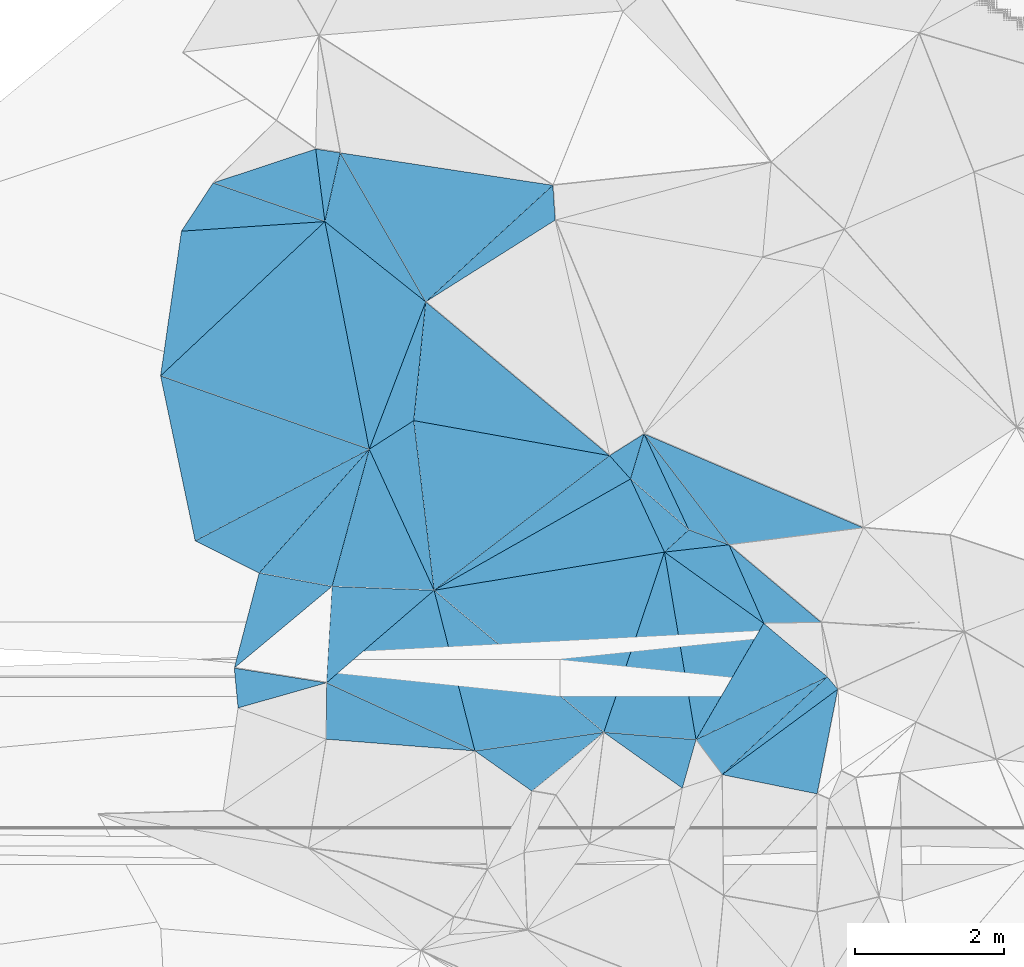
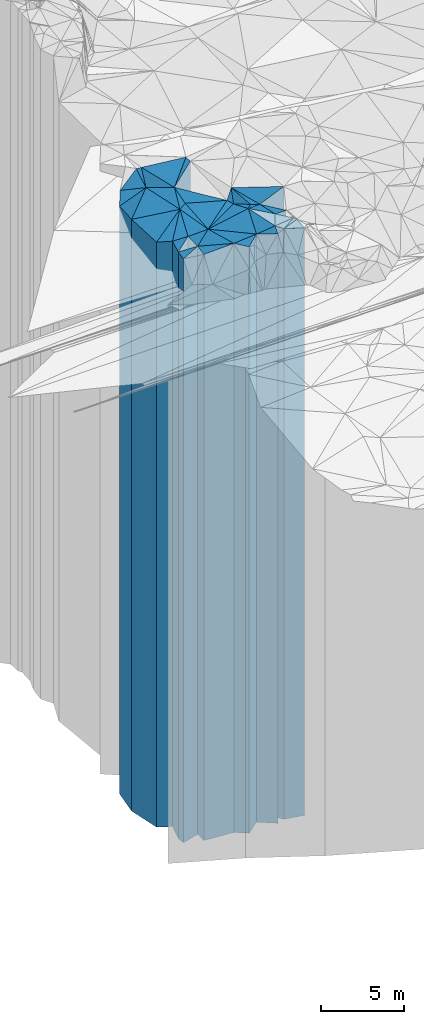
# One storey, part 215 of 275: 42 plates.
"""IFC2X3 building model written with IfcOpenShell, lengths in millimetres."""

import ifcopenshell
import ifcopenshell.guid

model = None  # the IFC model being written
_history = None  # IfcOwnerHistory: only IFC2X3 demands one
_inside = {}  # id of a spatial element -> (the spatial element, [elements in it])
_under = {}  # id of a project, library or spatial element -> (it, [spatial elements below it])
_declared = {}  # id of a project -> (the project, [libraries it declares])
_typed = {}  # id of a type object -> (the type object, [elements of that type])
_made_of = {}  # id of a material, layer set ... -> (it, [elements and type objects made of it])


def new_model(schema):
    """Start an empty IFC model of exactly this schema.

    Asked for "IFC4X3", IfcOpenShell would pick the latest addendum, in which some entities
    have other attributes; the version numbers below select the first issue.
    IFC2X3 requires an IfcOwnerHistory on every rooted entity: one is made here for all.
    """
    global model, _history
    if schema == "IFC4X3":
        model = ifcopenshell.file(schema_version=(4, 3, 0, 0))
    else:
        model = ifcopenshell.file(schema=schema)
    _inside.clear()
    _under.clear()
    _declared.clear()
    _typed.clear()
    _made_of.clear()
    _history = None
    if model.schema == "IFC2X3":
        org = make("IfcOrganization", Name="unknown")
        user = make(
            "IfcPersonAndOrganization",
            ThePerson=make("IfcPerson", FamilyName="unknown"),
            TheOrganization=org,
        )
        app = make(
            "IfcApplication",
            ApplicationDeveloper=org,
            Version="unknown",
            ApplicationFullName="unknown",
            ApplicationIdentifier="unknown",
        )
        _history = make(
            "IfcOwnerHistory",
            OwningUser=user,
            OwningApplication=app,
            ChangeAction="ADDED",
            CreationDate=0,
        )
    return model


def make(cls, **values):
    """One entity of the class cls with the attributes given. An attribute that is None is left unset."""
    return model.create_entity(
        cls, **{name: value for name, value in values.items() if value is not None}
    )


def rooted(cls, **values):
    """An entity with a GlobalId (a new one), such as an element, a storey or a relation."""
    return make(cls, GlobalId=ifcopenshell.guid.new(), OwnerHistory=_history, **values)


def si_unit(unit_type, name, prefix=None):
    """IfcSIUnit, for example si_unit("LENGTHUNIT", "METRE", prefix="MILLI")."""
    return make("IfcSIUnit", UnitType=unit_type, Prefix=prefix, Name=name)


def assignment(units):
    """IfcUnitAssignment: the units of a project."""
    return None if units is None else make("IfcUnitAssignment", Units=units)


def point(xyz):
    """IfcCartesianPoint."""
    return None if xyz is None else make("IfcCartesianPoint", Coordinates=xyz)


def direction(xyz):
    """IfcDirection."""
    return None if xyz is None else make("IfcDirection", DirectionRatios=xyz)


def frame(location, z_axis=None, x_axis=None):
    """IfcAxis2Placement3D, a coordinate frame: its origin and axes. An axis left out is left unset."""
    return make(
        "IfcAxis2Placement3D",
        Location=point(location),
        Axis=direction(z_axis),
        RefDirection=direction(x_axis),
    )


def origin_with_axes():
    """The frame at (0, 0, 0) with the z axis (0, 0, 1) and the x axis (1, 0, 0) written out."""
    return frame((0.0, 0.0, 0.0), z_axis=(0.0, 0.0, 1.0), x_axis=(1.0, 0.0, 0.0))


def place(relative_to, where):
    """IfcLocalPlacement: puts the frame where relative to a parent placement (None: the world)."""
    return make(
        "IfcLocalPlacement", PlacementRelTo=relative_to, RelativePlacement=where
    )


def context(
    kind, dimensions, precision=None, world=None, true_north=None, identifier=None
):
    """IfcGeometricRepresentationContext, for example the 3D "Model" context."""
    return make(
        "IfcGeometricRepresentationContext",
        ContextIdentifier=identifier,
        ContextType=kind,
        CoordinateSpaceDimension=dimensions,
        Precision=precision,
        WorldCoordinateSystem=world,
        TrueNorth=true_north,
    )


def subcontext(parent, identifier, kind, view, scale=None):
    """IfcGeometricRepresentationSubContext, for example "Body" below "Model"."""
    return make(
        "IfcGeometricRepresentationSubContext",
        ContextIdentifier=identifier,
        ContextType=kind,
        ParentContext=parent,
        TargetScale=scale,
        TargetView=view,
    )


def project(units=None, contexts=None):
    """IfcProject with its units and contexts."""
    return rooted(
        "IfcProject",
        Name="project",
        RepresentationContexts=contexts,
        UnitsInContext=assignment(units),
    )


def spatial(cls, under=None, at=None, **own):
    """A site, building, storey or space (cls), placed at a placement, below another one or the project."""
    s = rooted(cls, ObjectPlacement=at, **own)
    if under is not None:
        _under.setdefault(under.id(), (under, []))[1].append(s)
    return s


def faces_of(points, faces, orient=None, outer=None):
    """IfcFace entities. A face is a list of loops; a loop is a list of indices into points, from 0.

    orient and outer hold one flag for each loop. By default every Orientation is true, the
    first loop of a face is its IfcFaceOuterBound and the others are IfcFaceBound.
    """
    made = []
    for i, loops in enumerate(faces):
        bounds = []
        for j, loop in enumerate(loops):
            is_outer = j == 0 if outer is None else outer[i][j]
            bounds.append(
                make(
                    "IfcFaceOuterBound" if is_outer else "IfcFaceBound",
                    Bound=make("IfcPolyLoop", Polygon=[points[k] for k in loop]),
                    Orientation=True if orient is None else orient[i][j],
                )
            )
        made.append(make("IfcFace", Bounds=bounds))
    return made


def faceted_brep(points, faces, orient=None, outer=None, voids=None):
    """IfcFacetedBrep: a solid bounded by flat faces; with voids (closed shells), ...WithVoids."""
    shared = [point(p) for p in points]
    hull = make("IfcClosedShell", CfsFaces=faces_of(shared, faces, orient, outer))
    if voids is None:
        return make("IfcFacetedBrep", Outer=hull)
    return make(
        "IfcFacetedBrepWithVoids",
        Outer=hull,
        Voids=[
            make(cls, CfsFaces=faces_of(shared, fs, o, b)) for cls, fs, o, b in voids
        ],
    )


def shape(context_of_items, identifier, shape_type, items):
    """IfcShapeRepresentation: the items that make up one representation, for example the "Body"."""
    return make(
        "IfcShapeRepresentation",
        ContextOfItems=context_of_items,
        RepresentationIdentifier=identifier,
        RepresentationType=shape_type,
        Items=items,
    )


def material(Name=None, Category=None):
    """IfcMaterial."""
    return make("IfcMaterial", Name=Name, Category=Category)


def made_of(thing, what):
    """Note that an element or type object is made of a material, layer set ...; save() writes the relation."""
    if what is not None:
        _made_of.setdefault(what.id(), (what, []))[1].append(thing)
    return thing


def type_object(cls, material=None, **own):
    """A type object (cls), such as IfcWallType, which elements share."""
    return made_of(rooted(cls, **own), material)


def element(
    cls,
    number,
    at=None,
    inside=None,
    cuts=None,
    type_object=None,
    material=None,
    context=None,
    identifier="Body",
    shape_type=None,
    held_by="IfcProductDefinitionShape",
    body=None,
    shapes=None,
    **own,
):
    """One element of the class cls, such as IfcWall. Its Tag is "e" and its number.

    at: its placement. inside: the storey or other place that contains it. cuts: it is an
    opening in that element (IfcRelVoidsElement). A single representation is given by context,
    identifier, shape_type and body (its items); several are given by shapes. held_by: the class
    of the entity that holds the representations. save() writes the other relations.
    """
    e = rooted(cls, Tag="e%d" % number, ObjectPlacement=at, **own)
    if body is not None:
        shapes = [shape(context, identifier, shape_type, body)]
    if shapes is not None:
        e.Representation = make(held_by, Representations=shapes)
    if inside is not None:
        _inside.setdefault(inside.id(), (inside, []))[1].append(e)
    if cuts is not None:
        rooted(
            "IfcRelVoidsElement", RelatingBuildingElement=cuts, RelatedOpeningElement=e
        )
    if type_object is not None:
        _typed.setdefault(type_object.id(), (type_object, []))[1].append(e)
    return made_of(e, material)


def aggregate(whole, parts):
    """IfcRelAggregates: a whole, such as a stair, and the parts it consists of."""
    return rooted("IfcRelAggregates", RelatingObject=whole, RelatedObjects=parts)


def save(model, path):
    """Write the relations noted so far, then the file.

    IfcRelAggregates (storeys below a building ...), IfcRelContainedInSpatialStructure (elements
    in a storey), IfcRelDefinesByType, IfcRelAssociatesMaterial and IfcRelDeclares: one each for
    every whole, place, type object, material and project.
    """
    for whole, parts in _under.values():
        aggregate(whole, parts)
    for where, things in _inside.values():
        rooted(
            "IfcRelContainedInSpatialStructure",
            RelatedElements=things,
            RelatingStructure=where,
        )
    for kind, things in _typed.values():
        rooted("IfcRelDefinesByType", RelatedObjects=things, RelatingType=kind)
    for what, things in _made_of.values():
        rooted("IfcRelAssociatesMaterial", RelatedObjects=things, RelatingMaterial=what)
    for by, libraries in _declared.values():
        rooted("IfcRelDeclares", RelatingContext=by, RelatedDefinitions=libraries)
    model.write(path)


model = new_model("IFC2X3")

# Units and contexts
model_context = context("Model", 3, precision=1e-05, world=origin_with_axes())
body_context = subcontext(model_context, "Body", "Model", "MODEL_VIEW")
ifc_project = project(units=[si_unit("LENGTHUNIT", "METRE", prefix="MILLI"), si_unit("AREAUNIT", "SQUARE_METRE"), si_unit("VOLUMEUNIT", "CUBIC_METRE"), si_unit("MASSUNIT", "GRAM", prefix="KILO"), si_unit("TIMEUNIT", "SECOND"), si_unit("PLANEANGLEUNIT", "RADIAN"), si_unit("SOLIDANGLEUNIT", "STERADIAN"), si_unit("THERMODYNAMICTEMPERATUREUNIT", "DEGREE_CELSIUS"), si_unit("LUMINOUSINTENSITYUNIT", "LUMEN")], contexts=[model_context])

# Site, building, storey
site_placement = place(None, origin_with_axes())
site = spatial("IfcSite", under=ifc_project, at=site_placement, CompositionType="ELEMENT")
building_placement = place(site_placement, origin_with_axes())
building = spatial("IfcBuilding", under=site, at=building_placement, Name="Undefined", CompositionType="ELEMENT")
storey_placement = place(building_placement, origin_with_axes())
storey = spatial("IfcBuildingStorey", under=building, at=storey_placement, Name="Undefined", CompositionType="ELEMENT", Elevation=0.0)

# Plates
ifc_material = material()
plate_type_1 = type_object("IfcPlateType", PredefinedType="NOTDEFINED")
plate_1_placement = place(storey_placement, frame((-133694.643315546, 67817.0549989382, 29399.0), z_axis=(0.143038411960058, -0.989717137723676, 0.0), x_axis=(-0.989717137723674, -0.143038411960065, 0.0)))
element("IfcPlate", 1, at=plate_1_placement, inside=storey, type_object=plate_type_1, material=ifc_material, Name="00", context=body_context, shape_type="Brep", body=[
    faceted_brep([(0.0, -21691.0, 0.0), (1066.72058105469, -21571.0, 641.098510742188), (1066.72058105469, 21571.0, 641.098510742188), (0.0, 21571.0, 0.0), (1744.50561523438, -21761.0, 1.45519152283669e-11), (1744.50561523438, 21571.0, 1.45519152283669e-11)], [[[0, 1, 2, 3]], [[1, 4, 5, 2]], [[4, 0, 3, 5]], [[5, 3, 2]], [[4, 1, 0]]]),
])
plate_type_2 = type_object("IfcPlateType", PredefinedType="NOTDEFINED")
plate_2_placement = place(storey_placement, frame((-135968.442269648, 69720.0889755981, 29459.0), z_axis=(0.969171816561967, 0.246385855888637, 0.0), x_axis=(0.246385855888648, -0.969171816561965, 0.0)))
element("IfcPlate", 2, at=plate_2_placement, inside=storey, type_object=plate_type_2, material=ifc_material, Name="00", context=body_context, shape_type="Brep", body=[
    faceted_brep([(-1.45519152283669e-11, -21631.0, 0.0), (2404.5988769531, -21631.0, 1734.82116699219), (2404.5988769531, 21631.0, 1734.82116699219), (-1.45519152283669e-11, 21631.0, 0.0), (2221.03588867189, -21701.0, 6.95581547915936e-09), (2221.03588867189, 21631.0, 6.95581547915936e-09)], [[[0, 1, 2, 3]], [[1, 4, 5, 2]], [[4, 0, 3, 5]], [[5, 3, 2]], [[4, 1, 0]]]),
])
plate_type_3 = type_object("IfcPlateType", PredefinedType="NOTDEFINED")
plate_3_placement = place(storey_placement, frame((-132642.138099084, 67068.7684433182, 29459.0), z_axis=(-0.962527066959694, 0.271185628988647, 0.0), x_axis=(0.271185628988662, 0.96252706695969, 0.0)))
element("IfcPlate", 3, at=plate_3_placement, inside=storey, type_object=plate_type_3, material=ifc_material, Name="00", context=body_context, shape_type="Brep", body=[
    faceted_brep([(3.63797880709171e-12, -21741.0, 0.0), (434.821777343761, -21631.0, 1215.98937988281), (434.821777343761, 21631.0, 1215.98937988281), (-1.45519152283669e-11, 21631.0, 0.0), (674.759216308605, -21861.0, 5.23868948221207e-10), (674.759216308605, 21631.0, 5.23868948221207e-10)], [[[0, 1, 2, 3]], [[1, 4, 5, 2]], [[4, 0, 3, 5]], [[5, 3, 2]], [[4, 1, 0]]]),
])
plate_type_4 = type_object("IfcPlateType", PredefinedType="NOTDEFINED")
plate_4_placement = place(storey_placement, frame((-132109.751318395, 67249.5011624015, 29274.0), z_axis=(-0.594073749986289, 0.804410578981423, 0.0), x_axis=(0.804410578981428, 0.594073749986282, 0.0)))
element("IfcPlate", 4, at=plate_4_placement, inside=storey, type_object=plate_type_4, material=ifc_material, Name="00", context=body_context, shape_type="Brep", body=[
    faceted_brep([(-1.45519152283669e-11, -22006.0, 0.0), (1913.57336425781, -21496.0, 218.029632568359), (1913.57336425781, 21446.0, 218.029632568359), (-1.45519152283669e-11, 21446.0, 0.0), (1926.34362792969, -21446.0, -1.76660250872374e-08), (1926.34362792969, 21446.0, -1.76660250872374e-08)], [[[0, 1, 2, 3]], [[1, 4, 5, 2]], [[4, 0, 3, 5]], [[5, 3, 2]], [[4, 1, 0]]]),
])
plate_type_5 = type_object("IfcPlateType", PredefinedType="NOTDEFINED")
plate_5_placement = place(storey_placement, frame((-135968.442269648, 69720.0889755981, 29414.0), z_axis=(-0.0375165729839207, -0.999296005571694, 0.0), x_axis=(-0.999296005571694, 0.0375165729839191, 0.0)))
element("IfcPlate", 5, at=plate_5_placement, inside=storey, type_object=plate_type_5, material=ifc_material, Name="00", context=body_context, shape_type="Brep", body=[
    faceted_brep([(0.0, -21676.0, -1.45519152283669e-11), (1394.62561035153, -21676.0, 1292.25366210936), (1394.62561035153, 21586.0, 1292.25366210936), (0.0, 21586.0, -1.45519152283669e-11), (1368.5393066406, -21586.0, 4.93309926241636e-09), (1368.5393066406, 21586.0, 4.93309926241636e-09)], [[[0, 1, 2, 3]], [[1, 4, 5, 2]], [[4, 0, 3, 5]], [[5, 3, 2]], [[4, 1, 0]]]),
])
plate_type_6 = type_object("IfcPlateType", PredefinedType="NOTDEFINED")
plate_6_placement = place(storey_placement, frame((-135421.210464797, 67567.5236800124, 29459.0), z_axis=(-0.969171816561967, -0.246385855888637, 0.0), x_axis=(-0.246385855888645, 0.969171816561965, 0.0)))
element("IfcPlate", 6, at=plate_6_placement, inside=storey, type_object=plate_type_6, material=ifc_material, Name="00", context=body_context, shape_type="Brep", body=[
    faceted_brep([(2.91038304567337e-11, -21701.0, -1.45519152283669e-11), (1375.5294189453, -21631.0, 1702.94421386716), (1375.5294189453, 21631.0, 1702.94421386716), (-1.45519152283669e-11, 21631.0, 0.0), (2221.03588867188, -21631.0, 6.91215973347425e-09), (2221.03588867189, 21631.0, 6.95581547915936e-09)], [[[0, 1, 2, 3]], [[1, 4, 5, 2]], [[4, 0, 3, 5]], [[5, 3, 2]], [[4, 1, 0]]]),
])
plate_type_7 = type_object("IfcPlateType", PredefinedType="NOTDEFINED")
plate_7_placement = place(storey_placement, frame((-136837.024032435, 71610.2915365303, 29359.0), z_axis=(0.747102197484397, -0.664709189430977, 0.0), x_axis=(-0.664709189430975, -0.747102197484398, 0.0)))
element("IfcPlate", 7, at=plate_7_placement, inside=storey, type_object=plate_type_7, material=ifc_material, Name="00", context=body_context, shape_type="Brep", body=[
    faceted_brep([(0.0, -22351.0, 0.0), (1705.50207519532, -21641.0, 849.507263183594), (1705.50207519532, 21531.0, 849.507263183594), (0.0, 21531.0, 0.0), (2219.63964843751, -21531.0, -2.14495230466127e-08), (2219.63964843751, 21531.0, -2.14495230466127e-08)], [[[0, 1, 2, 3]], [[1, 4, 5, 2]], [[4, 0, 3, 5]], [[5, 3, 2]], [[4, 1, 0]]]),
])
plate_type_8 = type_object("IfcPlateType", PredefinedType="NOTDEFINED")
plate_8_placement = place(storey_placement, frame((-136837.024032435, 71610.2915365303, 29339.0), z_axis=(0.465901457936678, -0.884836612879732, 0.0), x_axis=(-0.884836612879734, -0.465901457936675, 0.0)))
element("IfcPlate", 8, at=plate_8_placement, inside=storey, type_object=plate_type_8, material=ifc_material, Name="00", context=body_context, shape_type="Brep", body=[
    faceted_brep([(0.0, -22371.0, -1.45519152283669e-11), (2078.10424804688, -21551.0, 779.924560546875), (2078.10424804688, 21511.0, 779.924560546875), (0.0, 21511.0, -1.45519152283669e-11), (2636.15258789061, -21511.0, -1.38970790430903e-08), (2636.15258789061, 21511.0, -1.38970790430903e-08)], [[[0, 1, 2, 3]], [[1, 4, 5, 2]], [[4, 0, 3, 5]], [[5, 3, 2]], [[4, 1, 0]]]),
])
plate_type_9 = type_object("IfcPlateType", PredefinedType="NOTDEFINED")
plate_9_placement = place(storey_placement, frame((-132881.824051758, 70232.0342627034, 29379.0), z_axis=(0.986157170939888, 0.165813250989892, 0.0), x_axis=(0.165813250989896, -0.986157170939887, 0.0)))
element("IfcPlate", 9, at=plate_9_placement, inside=storey, type_object=plate_type_9, material=ifc_material, Name="00", context=body_context, shape_type="Brep", body=[
    faceted_brep([(0.0, -21841.0, 0.0), (1161.12561035156, -21551.0, 1152.73034667969), (1161.12561035156, 21551.0, 1152.73034667969), (0.0, 21551.0, 0.0), (2549.07836914063, -21941.0, -9.02218744158745e-09), (2549.07836914063, 21551.0, -9.02218744158745e-09)], [[[0, 1, 2, 3]], [[1, 4, 5, 2]], [[4, 0, 3, 5]], [[5, 3, 2]], [[4, 1, 0]]]),
])
plate_type_10 = type_object("IfcPlateType", PredefinedType="NOTDEFINED")
plate_10_placement = place(storey_placement, frame((-133155.994527571, 71816.4996457878, 29499.0), z_axis=(0.90583815325824, 0.42362393712077, 0.0), x_axis=(0.423623937120775, -0.905838153258237, 0.0)))
element("IfcPlate", 10, at=plate_10_placement, inside=storey, type_object=plate_type_10, material=ifc_material, Name="00", context=body_context, shape_type="Brep", body=[
    faceted_brep([(0.0, -22391.0, -1.45519152283669e-11), (1828.88769531249, -21671.0, 401.45971679686), (1828.88769531249, 21671.0, 401.45971679686), (0.0, 21671.0, -1.45519152283669e-11), (1420.31689453125, -21731.0, -1.22381607070565e-08), (1420.31689453125, 21671.0, -1.22381607070565e-08)], [[[0, 1, 2, 3]], [[1, 4, 5, 2]], [[4, 0, 3, 5]], [[5, 3, 2]], [[4, 1, 0]]]),
])
plate_type_11 = type_object("IfcPlateType", PredefinedType="NOTDEFINED")
plate_11_placement = place(storey_placement, frame((-137431.281867819, 74660.5140898999, 29439.0), z_axis=(0.0666113430044553, -0.997778998066778, 0.0), x_axis=(-0.997778998066777, -0.0666113430044609, 0.0)))
element("IfcPlate", 11, at=plate_11_placement, inside=storey, type_object=plate_type_11, material=ifc_material, Name="00", context=body_context, shape_type="Brep", body=[
    faceted_brep([(2.91038304567337e-11, -22221.0, -1.45519152283669e-11), (2334.96997070315, -21911.0, 1915.83288574217), (2334.96997070315, 21611.0, 1915.83288574217), (2.91038304567337e-11, 21611.0, -1.45519152283669e-11), (1926.57727050787, -21611.0, 1.3329554349184e-08), (1926.57727050787, 21611.0, 1.3329554349184e-08)], [[[0, 1, 2, 3]], [[1, 4, 5, 2]], [[4, 0, 3, 5]], [[5, 3, 2]], [[4, 1, 0]]]),
])
plate_type_12 = type_object("IfcPlateType", PredefinedType="NOTDEFINED")
plate_12_placement = place(storey_placement, frame((-136241.298913571, 71993.9731529184, 29559.0), z_axis=(0.175965855926395, 0.984396270588268, 0.0), x_axis=(0.984396270588267, -0.175965855926401, 0.0)))
element("IfcPlate", 12, at=plate_12_placement, inside=storey, type_object=plate_type_12, material=ifc_material, Name="00", context=body_context, shape_type="Brep", body=[
    faceted_brep([(0.0, -22151.0, 1.45519152283669e-11), (-122.009300231934, -22301.0, 1594.14990234376), (-122.009300231934, 21731.0, 1594.14990234376), (0.0, 21731.0, 1.45519152283669e-11), (2665.37060546875, -21731.0, -6.73753675073385e-09), (2665.37060546875, 21731.0, -6.73753675073385e-09)], [[[0, 1, 2, 3]], [[1, 4, 5, 2]], [[4, 0, 3, 5]], [[5, 3, 2]], [[4, 1, 0]]]),
])
plate_type_13 = type_object("IfcPlateType", PredefinedType="NOTDEFINED")
plate_13_placement = place(storey_placement, frame((-136241.298913571, 71993.9731529184, 29769.0), z_axis=(-0.994954113125758, 0.100331016012676, 0.0), x_axis=(0.100331016012676, 0.994954113125758, 0.0)))
element("IfcPlate", 13, at=plate_13_placement, inside=storey, type_object=plate_type_13, material=ifc_material, Name="00", context=body_context, shape_type="Brep", body=[
    faceted_brep([(0.0, -21941.0, 2.91038304567337e-11), (-441.515319824219, -21941.0, 554.223999023438), (-441.515319824219, 21941.0, 554.223999023438), (0.0, 21941.0, 2.91038304567337e-11), (1598.81201171876, -22091.0, 5.29689714312553e-09), (1598.81201171876, 21941.0, 5.29689714312553e-09)], [[[0, 1, 2, 3]], [[1, 4, 5, 2]], [[4, 0, 3, 5]], [[5, 3, 2]], [[4, 1, 0]]]),
])
plate_type_14 = type_object("IfcPlateType", PredefinedType="NOTDEFINED")
plate_14_placement = place(storey_placement, frame((-135968.442269648, 69720.0889755981, 29459.0), z_axis=(-0.608961544895486, 0.793199745863867, 0.0), x_axis=(0.793199745863867, 0.608961544895486, 0.0)))
element("IfcPlate", 14, at=plate_14_placement, inside=storey, type_object=plate_type_14, material=ifc_material, Name="00", context=body_context, shape_type="Brep", body=[
    faceted_brep([(-1.45519152283669e-11, -21631.0, 0.0), (1168.27819824218, -22251.0, 1969.80358886722), (1168.27819824218, 21631.0, 1969.80358886722), (-1.45519152283669e-11, 21631.0, 0.0), (2963.8488769531, -21831.0, 2.86090653389692e-08), (2963.8488769531, 21631.0, 2.86090653389692e-08)], [[[0, 1, 2, 3]], [[1, 4, 5, 2]], [[4, 0, 3, 5]], [[5, 3, 2]], [[4, 1, 0]]]),
])
plate_type_15 = type_object("IfcPlateType", PredefinedType="NOTDEFINED")
plate_15_placement = place(storey_placement, frame((-135968.442269648, 69720.0889755981, 29459.0), z_axis=(-0.493107680187151, 0.869968284330209, 0.0), x_axis=(0.869968284330204, 0.49310768018716, 0.0)))
element("IfcPlate", 15, at=plate_15_placement, inside=storey, type_object=plate_type_15, material=ifc_material, Name="00", context=body_context, shape_type="Brep", body=[
    faceted_brep([(-1.45519152283669e-11, -21631.0, 0.0), (2935.22460937497, -21831.0, 410.920867919936), (2935.22460937497, 21631.0, 410.920867919936), (-1.45519152283669e-11, 21631.0, 0.0), (3024.9133300781, -21661.0, -2.4156179279089e-09), (3024.9133300781, 21631.0, -2.4156179279089e-09)], [[[0, 1, 2, 3]], [[1, 4, 5, 2]], [[4, 0, 3, 5]], [[5, 3, 2]], [[4, 1, 0]]]),
])
plate_type_16 = type_object("IfcPlateType", PredefinedType="NOTDEFINED")
plate_16_placement = place(storey_placement, frame((-133617.518115447, 71524.9589490844, 29474.0), z_axis=(0.744807162935643, 0.667279768942352, 0.0), x_axis=(0.667279768942338, -0.744807162935655, 0.0)))
element("IfcPlate", 16, at=plate_16_placement, inside=storey, type_object=plate_type_16, material=ifc_material, Name="00", context=body_context, shape_type="Brep", body=[
    faceted_brep([(0.0, -21816.0, -2.18278728425503e-11), (90.8237533569627, -22416.0, 538.285278320283), (90.8237533569627, 21646.0, 538.285278320283), (0.0, 21646.0, -2.18278728425503e-11), (420.594818115263, -21646.0, 3.36876837536693e-09), (420.594818115263, 21646.0, 3.36876837536693e-09)], [[[0, 1, 2, 3]], [[1, 4, 5, 2]], [[4, 0, 3, 5]], [[5, 3, 2]], [[4, 1, 0]]]),
])
plate_type_17 = type_object("IfcPlateType", PredefinedType="NOTDEFINED")
plate_17_placement = place(storey_placement, frame((-137431.281867819, 74660.5140898999, 29744.0), z_axis=(-0.991969754680084, -0.126475316959215, 0.0), x_axis=(-0.126475316959204, 0.991969754680086, 0.0)))
element("IfcPlate", 17, at=plate_17_placement, inside=storey, type_object=plate_type_17, material=ifc_material, Name="00", context=body_context, shape_type="Brep", body=[
    faceted_brep([(0.0, -21916.0, 1.45519152283669e-11), (703.903686523452, -21926.0, 1420.04211425781), (703.903686523452, 21916.0, 1420.04211425781), (0.0, 21916.0, 1.45519152283669e-11), (980.815979003892, -22766.0, 6.43194653093815e-09), (980.815979003892, 21916.0, 6.43194653093815e-09)], [[[0, 1, 2, 3]], [[1, 4, 5, 2]], [[4, 0, 3, 5]], [[5, 3, 2]], [[4, 1, 0]]]),
])
plate_type_18 = type_object("IfcPlateType", PredefinedType="NOTDEFINED")
plate_18_placement = place(storey_placement, frame((-136837.024032435, 71610.2915365303, 29744.0), z_axis=(-0.93386112540604, 0.357635846155505, 0.0), x_axis=(0.357635846155495, 0.933861125406044, 0.0)))
element("IfcPlate", 18, at=plate_18_placement, inside=storey, type_object=plate_type_18, material=ifc_material, Name="00", context=body_context, shape_type="Brep", body=[
    faceted_brep([(0.0, -21966.0, 0.0), (2635.9562988281, -21916.0, 1645.8232421875), (2635.9562988281, 21916.0, 1645.8232421875), (0.0, 21916.0, 1.45519152283669e-11), (2114.26098632813, -22116.0, 1.16415321826935e-09), (2114.26098632813, 21916.0, 1.16415321826935e-09)], [[[0, 1, 2, 3]], [[1, 4, 5, 2]], [[4, 0, 3, 5]], [[5, 3, 2]], [[4, 1, 0]]]),
])
plate_type_19 = type_object("IfcPlateType", PredefinedType="NOTDEFINED")
plate_19_placement = place(storey_placement, frame((-139353.580211905, 74532.1821908107, 29439.0), z_axis=(-0.0666113430044553, 0.997778998066778, 0.0), x_axis=(0.997778998066778, 0.0666113430044554, 0.0)))
element("IfcPlate", 19, at=plate_19_placement, inside=storey, type_object=plate_type_19, material=ifc_material, Name="00", context=body_context, shape_type="Brep", body=[
    faceted_brep([(0.0, -21611.0, 1.45519152283669e-11), (466.786376953096, -22231.0, 617.26049804689), (466.786376953096, 21611.0, 617.26049804689), (2.91038304567337e-11, 21611.0, -1.45519152283669e-11), (1926.57727050781, -22221.0, 1.33732100948691e-08), (1926.57727050787, 21611.0, 1.3329554349184e-08)], [[[0, 1, 2, 3]], [[1, 4, 5, 2]], [[4, 0, 3, 5]], [[5, 3, 2]], [[4, 1, 0]]]),
])
plate_type_20 = type_object("IfcPlateType", PredefinedType="NOTDEFINED")
plate_20_placement = place(storey_placement, frame((-134345.602101279, 74680.0173811225, 29844.0), z_axis=(-0.99771952689471, -0.0674962639928778, 0.0), x_axis=(-0.0674962639928997, 0.997719526894708, 0.0)))
element("IfcPlate", 20, at=plate_20_placement, inside=storey, type_object=plate_type_20, material=ifc_material, Name="00", context=body_context, shape_type="Brep", body=[
    faceted_brep([(1.45519152283669e-11, -22676.0, 2.91038304567337e-11), (-975.676452636733, -22016.0, 1805.2576904297), (-975.676452636733, 22016.0, 1805.2576904297), (1.45519152283669e-11, 22016.0, 2.91038304567337e-11), (468.187988281265, -22696.0, 2.66300048679113e-09), (468.187988281265, 22016.0, 2.66300048679113e-09)], [[[0, 1, 2, 3]], [[1, 4, 5, 2]], [[4, 0, 3, 5]], [[5, 3, 2]], [[4, 1, 0]]]),
])
plate_type_21 = type_object("IfcPlateType", PredefinedType="NOTDEFINED")
plate_21_placement = place(storey_placement, frame((-137431.281867819, 74660.5140898999, 29744.0), z_axis=(0.623097980813835, 0.782143788766312, 0.0), x_axis=(0.782143788766313, -0.623097980813835, 0.0)))
element("IfcPlate", 21, at=plate_21_placement, inside=storey, type_object=plate_type_21, material=ifc_material, Name="00", context=body_context, shape_type="Brep", body=[
    faceted_brep([(0.0, -21916.0, 1.45519152283669e-11), (-414.010009765625, -22776.0, 848.407775878914), (-414.010009765625, 21916.0, 848.407775878914), (0.0, 21916.0, 1.45519152283669e-11), (1726.52832031247, -22116.0, -7.13771441951394e-09), (1726.52832031247, 21916.0, -7.13771441951394e-09)], [[[0, 1, 2, 3]], [[1, 4, 5, 2]], [[4, 0, 3, 5]], [[5, 3, 2]], [[4, 1, 0]]]),
])
plate_type_22 = type_object("IfcPlateType", PredefinedType="NOTDEFINED")
plate_22_placement = place(storey_placement, frame((-137226.456067813, 75582.0597434907, 29844.0), z_axis=(0.867450797065505, 0.497522979037572, 0.0), x_axis=(0.49752297903757, -0.867450797065506, 0.0)))
element("IfcPlate", 22, at=plate_22_placement, inside=storey, type_object=plate_type_22, material=ifc_material, Name="00", context=body_context, shape_type="Brep", body=[
    faceted_brep([(1.45519152283669e-11, -22676.0, 2.91038304567337e-11), (1794.84228515625, -22696.0, 2255.20312500001), (1794.84228515625, 22016.0, 2255.20312500001), (1.45519152283669e-11, 22016.0, 2.91038304567337e-11), (2302.54199218747, -22016.0, 2.57859937846661e-08), (2302.54199218747, 22016.0, 2.57859937846661e-08)], [[[0, 1, 2, 3]], [[1, 4, 5, 2]], [[4, 0, 3, 5]], [[5, 3, 2]], [[4, 1, 0]]]),
])
plate_type_23 = type_object("IfcPlateType", PredefinedType="NOTDEFINED")
plate_23_placement = place(storey_placement, frame((-137226.456067813, 75582.0597434907, 29744.0), z_axis=(-0.154398731049965, -0.988008619319771, 0.0), x_axis=(-0.988008619319777, 0.15439873104993, 0.0)))
element("IfcPlate", 23, at=plate_23_placement, inside=storey, type_object=plate_type_23, material=ifc_material, Name="00", context=body_context, shape_type="Brep", body=[
    faceted_brep([(1.45519152283669e-11, -22776.0, 0.0), (60.0841751098633, -21916.0, 942.119873046882), (60.0841751098633, 21916.0, 942.119873046882), (0.0, 21916.0, 1.45519152283669e-11), (332.866333007813, -22766.0, 1.3169483281672e-09), (332.866333007813, 21916.0, 1.3169483281672e-09)], [[[0, 1, 2, 3]], [[1, 4, 5, 2]], [[4, 0, 3, 5]], [[5, 3, 2]], [[4, 1, 0]]]),
])
plate_type_24 = type_object("IfcPlateType", PredefinedType="NOTDEFINED")
plate_24_placement = place(storey_placement, frame((-131552.520695703, 69278.1199124711, 29374.0), z_axis=(-0.0165367700044677, 0.999863258269759, 0.0), x_axis=(0.999863258269759, 0.0165367700044697, 0.0)))
element("IfcPlate", 24, at=plate_24_placement, inside=storey, type_object=plate_type_24, material=ifc_material, Name="00", context=body_context, shape_type="Brep", body=[
    faceted_brep([(0.0, -21556.0, -2.91038304567337e-11), (-447.599212646499, -21796.0, 1059.31811523439), (-447.599212646499, 21546.0, 1059.31811523439), (0.0, 21546.0, -2.18278728425503e-11), (770.778808593735, -21546.0, -4.68571670353413e-09), (770.778808593735, 21546.0, -4.68571670353413e-09)], [[[0, 1, 2, 3]], [[1, 4, 5, 2]], [[4, 0, 3, 5]], [[5, 3, 2]], [[4, 1, 0]]]),
])
plate_type_25 = type_object("IfcPlateType", PredefinedType="NOTDEFINED")
plate_25_placement = place(storey_placement, frame((-132881.824051758, 70232.0342627034, 29474.0), z_axis=(-0.672860803241192, 0.739769112265183, 0.0), x_axis=(0.739769112265176, 0.672860803241201, 0.0)))
element("IfcPlate", 25, at=plate_25_placement, inside=storey, type_object=plate_type_25, material=ifc_material, Name="00", context=body_context, shape_type="Brep", body=[
    faceted_brep([(6.82121026329696e-12, -21746.0, 2.91038304567337e-11), (322.552307128877, -21646.0, 1030.90246582031), (322.552307128877, 21646.0, 1030.90246582031), (0.0, 21646.0, -2.18278728425503e-11), (442.718872070276, -21756.0, 7.8580342233181e-10), (442.718872070276, 21646.0, 7.8580342233181e-10)], [[[0, 1, 2, 3]], [[1, 4, 5, 2]], [[4, 0, 3, 5]], [[5, 3, 2]], [[4, 1, 0]]]),
])
plate_type_26 = type_object("IfcPlateType", PredefinedType="NOTDEFINED")
plate_26_placement = place(storey_placement, frame((-132017.576409019, 70329.8913626978, 29499.0), z_axis=(-0.125584208936625, 0.992082963499405, 0.0), x_axis=(0.992082963499404, 0.125584208936632, 0.0)))
element("IfcPlate", 26, at=plate_26_placement, inside=storey, type_object=plate_type_26, material=ifc_material, Name="00", context=body_context, shape_type="Brep", body=[
    faceted_brep([(2.18278728425503e-11, -21671.0, 0.0), (-942.71069335939, -22391.0, 1617.80603027344), (-942.71069335939, 21671.0, 1617.80603027344), (0.0, 21671.0, -1.45519152283669e-11), (1816.03967285156, -22211.0, -2.7648638933897e-10), (1816.03967285156, 21671.0, -2.7648638933897e-10)], [[[0, 1, 2, 3]], [[1, 4, 5, 2]], [[4, 0, 3, 5]], [[5, 3, 2]], [[4, 1, 0]]]),
])
plate_type_27 = type_object("IfcPlateType", PredefinedType="NOTDEFINED")
plate_27_placement = place(storey_placement, frame((-135968.442269648, 69720.0889755981, 29459.0), z_axis=(-0.163624273039147, 0.98652273023606, 0.0), x_axis=(0.986522730236059, 0.163624273039154, 0.0)))
element("IfcPlate", 27, at=plate_27_placement, inside=storey, type_object=plate_type_27, material=ifc_material, Name="00", context=body_context, shape_type="Brep", body=[
    faceted_brep([(-1.45519152283669e-11, -21631.0, 0.0), (2840.17529296874, -21661.0, 1040.9150390625), (2840.17529296874, 21631.0, 1040.9150390625), (-1.45519152283669e-11, 21631.0, 0.0), (3128.78564453125, -21761.0, 2.57568899542093e-08), (3128.78564453125, 21631.0, 2.57568899542093e-08)], [[[0, 1, 2, 3]], [[1, 4, 5, 2]], [[4, 0, 3, 5]], [[5, 3, 2]], [[4, 1, 0]]]),
])
plate_type_28 = type_object("IfcPlateType", PredefinedType="NOTDEFINED")
plate_28_placement = place(storey_placement, frame((-133155.994527571, 71816.4996457878, 29474.0), z_axis=(0.958075157885625, -0.286517000965798, 0.0), x_axis=(-0.286517000965788, -0.958075157885628, 0.0)))
element("IfcPlate", 28, at=plate_28_placement, inside=storey, type_object=plate_type_28, material=ifc_material, Name="00", context=body_context, shape_type="Brep", body=[
    faceted_brep([(-1.45519152283669e-11, -22416.0, 0.0), (1060.24609374998, -21756.0, 945.081115722685), (1060.24609374998, 21646.0, 945.081115722685), (0.0, 21646.0, -2.18278728425503e-11), (631.2685546875, -21646.0, 1.65891833603382e-09), (631.2685546875, 21646.0, 1.65891833603382e-09)], [[[0, 1, 2, 3]], [[1, 4, 5, 2]], [[4, 0, 3, 5]], [[5, 3, 2]], [[4, 1, 0]]]),
])
plate_type_29 = type_object("IfcPlateType", PredefinedType="NOTDEFINED")
plate_29_placement = place(storey_placement, frame((-131552.520695703, 69278.1199124711, 29379.0), z_axis=(-0.914583869967225, -0.404396271985505, 0.0), x_axis=(-0.404396271985505, 0.914583869967225, 0.0)))
element("IfcPlate", 29, at=plate_29_placement, inside=storey, type_object=plate_type_29, material=ifc_material, Name="00", context=body_context, shape_type="Brep", body=[
    faceted_brep([(-1.45519152283669e-11, -21551.0, -1.45519152283669e-11), (1410.0, -21841.0, 830.0), (1410.0, 21551.0, 830.0), (0.0, 21551.0, 0.0), (1150.0, -21791.0, 6.81029632687569e-09), (1150.0, 21551.0, 6.81029632687569e-09)], [[[0, 1, 2, 3]], [[1, 4, 5, 2]], [[4, 0, 3, 5]], [[5, 3, 2]], [[4, 1, 0]]]),
])
plate_type_30 = type_object("IfcPlateType", PredefinedType="NOTDEFINED")
plate_30_placement = place(storey_placement, frame((-132017.576409019, 70329.8913626978, 29499.0), z_axis=(-0.349216179018674, -0.93704218705008, 0.0), x_axis=(-0.937042187050085, 0.349216179018662, 0.0)))
element("IfcPlate", 30, at=plate_30_placement, inside=storey, type_object=plate_type_30, material=ifc_material, Name="00", context=body_context, shape_type="Brep", body=[
    faceted_brep([(2.18278728425503e-11, -21671.0, 0.0), (775.663208007813, -21721.0, 393.505493164052), (775.663208007813, 21671.0, 393.505493164052), (0.0, 21671.0, -1.45519152283669e-11), (572.80010986331, -21731.0, -2.16459739021957e-09), (572.80010986331, 21671.0, -2.16459739021957e-09)], [[[0, 1, 2, 3]], [[1, 4, 5, 2]], [[4, 0, 3, 5]], [[5, 3, 2]], [[4, 1, 0]]]),
])
plate_type_31 = type_object("IfcPlateType", PredefinedType="NOTDEFINED")
plate_31_placement = place(storey_placement, frame((-130699.97832707, 68561.6902162087, 29299.0), z_axis=(-0.643346918862424, -0.765574778836284, 0.0), x_axis=(-0.765574778836287, 0.643346918862421, 0.0)))
element("IfcPlate", 31, at=plate_31_placement, inside=storey, type_object=plate_type_31, material=ifc_material, Name="00", context=body_context, shape_type="Brep", body=[
    faceted_brep([(1.45519152283669e-11, -21471.0, 2.91038304567337e-11), (804.150329589844, -22021.0, 1777.48205566409), (804.150329589844, 21471.0, 1777.48205566409), (1.45519152283669e-11, 21471.0, 2.91038304567337e-11), (1113.59777832031, -21631.0, -1.31331034936011e-09), (1113.59777832031, 21471.0, -1.31331034936011e-09)], [[[0, 1, 2, 3]], [[1, 4, 5, 2]], [[4, 0, 3, 5]], [[5, 3, 2]], [[4, 1, 0]]]),
])
plate_type_32 = type_object("IfcPlateType", PredefinedType="NOTDEFINED")
plate_32_placement = place(storey_placement, frame((-133694.643315546, 67817.0549989382, 29459.0), z_axis=(0.0797238399910876, 0.99681698888867, 0.0), x_axis=(0.99681698888867, -0.0797238399910978, 0.0)))
element("IfcPlate", 32, at=plate_32_placement, inside=storey, type_object=plate_type_32, material=ifc_material, Name="00", context=body_context, shape_type="Brep", body=[
    faceted_brep([(-1.45519152283669e-11, -21631.0, 0.0), (617.700622558594, -21761.0, 2472.09350585939), (617.700622558594, 21631.0, 2472.09350585939), (-1.45519152283669e-11, 21631.0, 0.0), (1239.43530273435, -21861.0, -3.65253072232008e-09), (1239.43530273435, 21631.0, -3.65253072232008e-09)], [[[0, 1, 2, 3]], [[1, 4, 5, 2]], [[4, 0, 3, 5]], [[5, 3, 2]], [[4, 1, 0]]]),
])
plate_type_33 = type_object("IfcPlateType", PredefinedType="NOTDEFINED")
plate_33_placement = place(storey_placement, frame((-133694.643315546, 67817.0549989382, 29459.0), z_axis=(-0.947757856762891, 0.318990665920197, 0.0), x_axis=(0.318990665920191, 0.947757856762893, 0.0)))
element("IfcPlate", 33, at=plate_33_placement, inside=storey, type_object=plate_type_33, material=ifc_material, Name="00", context=body_context, shape_type="Brep", body=[
    faceted_brep([(-1.45519152283669e-11, -21631.0, 0.0), (1078.29479980466, -21631.0, 2762.06079101568), (1078.29479980466, 21631.0, 2762.06079101568), (-1.45519152283669e-11, 21631.0, 0.0), (2548.09741210938, -21761.0, 9.28412191569805e-09), (2548.09741210938, 21631.0, 9.28412191569805e-09)], [[[0, 1, 2, 3]], [[1, 4, 5, 2]], [[4, 0, 3, 5]], [[5, 3, 2]], [[4, 1, 0]]]),
])
plate_type_34 = type_object("IfcPlateType", PredefinedType="NOTDEFINED")
plate_34_placement = place(storey_placement, frame((-137336.018192925, 69771.4318823434, 29414.0), z_axis=(0.0375165729839207, 0.999296005571694, 0.0), x_axis=(0.999296005571694, -0.0375165729839183, 0.0)))
element("IfcPlate", 34, at=plate_34_placement, inside=storey, type_object=plate_type_34, material=ifc_material, Name="00", context=body_context, shape_type="Brep", body=[
    faceted_brep([(-1.45519152283669e-11, -21586.0, -2.91038304567337e-11), (429.655151367188, -22296.0, 1856.28564453125), (429.655151367188, 21586.0, 1856.28564453125), (0.0, 21586.0, -1.45519152283669e-11), (1368.5393066406, -21676.0, 4.94037522003055e-09), (1368.5393066406, 21586.0, 4.93309926241636e-09)], [[[0, 1, 2, 3]], [[1, 4, 5, 2]], [[4, 0, 3, 5]], [[5, 3, 2]], [[4, 1, 0]]]),
])
plate_type_35 = type_object("IfcPlateType", PredefinedType="NOTDEFINED")
plate_35_placement = place(storey_placement, frame((-139633.449624193, 72593.4008436584, 29339.0), z_axis=(0.978698955960313, 0.205300641991675, 0.0), x_axis=(0.205300641991677, -0.978698955960312, 0.0)))
element("IfcPlate", 35, at=plate_35_placement, inside=storey, type_object=plate_type_35, material=ifc_material, Name="00", context=body_context, shape_type="Brep", body=[
    faceted_brep([(0.0, -22011.0, 2.91038304567337e-11), (1536.27600097658, -22371.0, 2535.02587890622), (1536.27600097658, 21511.0, 2535.02587890622), (0.0, 21511.0, -1.45519152283669e-11), (2259.4248046875, -21511.0, -1.67638063430786e-08), (2259.4248046875, 21511.0, -1.67638063430786e-08)], [[[0, 1, 2, 3]], [[1, 4, 5, 2]], [[4, 0, 3, 5]], [[5, 3, 2]], [[4, 1, 0]]]),
])
plate_type_36 = type_object("IfcPlateType", PredefinedType="NOTDEFINED")
plate_36_placement = place(storey_placement, frame((-130560.18007767, 68393.8913799055, 29274.0), z_axis=(0.594073749986279, -0.80441057898143, 0.0), x_axis=(-0.804410578981425, -0.594073749986287, 0.0)))
element("IfcPlate", 36, at=plate_36_placement, inside=storey, type_object=plate_type_36, material=ifc_material, Name="00", context=body_context, shape_type="Brep", body=[
    faceted_brep([(-1.45519152283669e-11, -21446.0, 0.0), (1055.3671875, -21766.0, 963.067993164033), (1055.3671875, 21446.0, 963.067993164033), (-1.45519152283669e-11, 21446.0, 0.0), (1926.34362792968, -22006.0, -9.60426405072212e-10), (1926.34362792969, 21446.0, -1.76660250872374e-08)], [[[0, 1, 2, 3]], [[1, 4, 5, 2]], [[4, 0, 3, 5]], [[5, 3, 2]], [[4, 1, 0]]]),
])
plate_type_37 = type_object("IfcPlateType", PredefinedType="NOTDEFINED")
plate_37_placement = place(storey_placement, frame((-130699.97832707, 68561.6902162087, 29299.0), z_axis=(0.432332707922618, -0.901714161838604, 0.0), x_axis=(-0.901714161838603, -0.43233270792262, 0.0)))
element("IfcPlate", 37, at=plate_37_placement, inside=storey, type_object=plate_type_37, material=ifc_material, Name="00", context=body_context, shape_type="Brep", body=[
    faceted_brep([(1.45519152283669e-11, -21471.0, 2.91038304567337e-11), (1838.51452636722, -21981.0, 573.728454589829), (1838.51452636722, 21471.0, 573.728454589829), (1.45519152283669e-11, 21471.0, 2.91038304567337e-11), (1950.92285156251, -22021.0, 8.92032403498888e-09), (1950.92285156251, 21471.0, 8.92032403498888e-09)], [[[0, 1, 2, 3]], [[1, 4, 5, 2]], [[4, 0, 3, 5]], [[5, 3, 2]], [[4, 1, 0]]]),
])
plate_type_38 = type_object("IfcPlateType", PredefinedType="NOTDEFINED")
plate_38_placement = place(storey_placement, frame((-137336.018192925, 69771.4318823434, 29359.0), z_axis=(-0.181839386025861, -0.98332824513981, 0.0), x_axis=(-0.983328245139811, 0.181839386025854, 0.0)))
element("IfcPlate", 38, at=plate_38_placement, inside=storey, type_object=plate_type_38, material=ifc_material, Name="00", context=body_context, shape_type="Brep", body=[
    faceted_brep([(2.91038304567337e-11, -21641.0, 7.27595761418343e-12), (1089.25158691406, -21621.0, 1313.02355957032), (1089.25158691406, 21531.0, 1313.02355957032), (0.0, 21531.0, 0.0), (992.975341796904, -21531.0, -2.48837750405073e-09), (992.975341796904, 21531.0, -2.48837750405073e-09)], [[[0, 1, 2, 3]], [[1, 4, 5, 2]], [[4, 0, 3, 5]], [[5, 3, 2]], [[4, 1, 0]]]),
])
plate_type_39 = type_object("IfcPlateType", PredefinedType="NOTDEFINED")
plate_39_placement = place(storey_placement, frame((-139633.449624193, 72593.4008436584, 29589.0), z_axis=(0.33166057607433, 0.943398782211448, 0.0), x_axis=(0.943398782211447, -0.331660576074334, 0.0)))
element("IfcPlate", 39, at=plate_39_placement, inside=storey, type_object=plate_type_39, material=ifc_material, Name="00", context=body_context, shape_type="Brep", body=[
    faceted_brep([(0.0, -21761.0, 3.63797880709171e-12), (1391.94238281253, -22071.0, 2680.484375), (1391.94238281253, 21761.0, 2680.484375), (0.0, 21761.0, 3.63797880709171e-12), (2964.20312500003, -22121.0, 1.74513843376189e-08), (2964.20312500003, 21761.0, 1.74513843376189e-08)], [[[0, 1, 2, 3]], [[1, 4, 5, 2]], [[4, 0, 3, 5]], [[5, 3, 2]], [[4, 1, 0]]]),
])
plate_type_40 = type_object("IfcPlateType", PredefinedType="NOTDEFINED")
plate_40_placement = place(storey_placement, frame((-137410.566962769, 68481.0666313719, 29389.0), z_axis=(0.999982402590785, -0.00593249599756627, 0.0), x_axis=(-0.00593249599756627, -0.999982402590785, 0.0)))
element("IfcPlate", 40, at=plate_40_placement, inside=storey, type_object=plate_type_40, material=ifc_material, Name="00", context=body_context, shape_type="Brep", body=[
    faceted_brep([(2.91038304567337e-11, -21701.0, -1.45519152283669e-11), (901.725036621137, -21771.0, 1994.74108886719), (901.725036621137, 21561.0, 1994.74108886719), (0.0, 21561.0, 0.0), (756.439025878921, -21561.0, 3.66708263754845e-09), (756.439025878921, 21561.0, 3.66708263754845e-09)], [[[0, 1, 2, 3]], [[1, 4, 5, 2]], [[4, 0, 3, 5]], [[5, 3, 2]], [[4, 1, 0]]]),
])
plate_type_41 = type_object("IfcPlateType", PredefinedType="NOTDEFINED")
plate_41_placement = place(storey_placement, frame((-136241.298913571, 71993.9731529184, 29459.0), z_axis=(0.541471845934102, -0.840718882897676, 0.0), x_axis=(-0.840718882897681, -0.541471845934095, 0.0)))
element("IfcPlate", 41, at=plate_41_placement, inside=storey, type_object=plate_type_41, material=ifc_material, Name="00", context=body_context, shape_type="Brep", body=[
    faceted_brep([(2.91038304567337e-11, -22251.0, 0.0), (1001.84851074225, -21631.0, 2059.44165039063), (1001.84851074225, 21631.0, 2059.44165039063), (-1.45519152283669e-11, 21631.0, 0.0), (708.59014892581, -22251.0, 2.91038304567337e-09), (708.59014892581, 21631.0, 2.91038304567337e-09)], [[[0, 1, 2, 3]], [[1, 4, 5, 2]], [[4, 0, 3, 5]], [[5, 3, 2]], [[4, 1, 0]]]),
])
plate_type_42 = type_object("IfcPlateType", PredefinedType="NOTDEFINED")
plate_42_placement = place(storey_placement, frame((-137410.566962769, 68481.0666313719, 29304.0), z_axis=(-0.157719674025619, -0.987483926160448, 0.0), x_axis=(-0.987483926160447, 0.157719674025623, 0.0)))
element("IfcPlate", 42, at=plate_42_placement, inside=storey, type_object=plate_type_42, material=ifc_material, Name="00", context=body_context, shape_type="Brep", body=[
    faceted_brep([(-2.91038304567337e-11, -21786.0, -7.27595761418343e-12), (1116.42297363281, -21476.0, 520.480407714851), (1116.42297363281, 21476.0, 520.480407714851), (0.0, 21476.0, 0.0), (1250.95959472653, -21676.0, -1.30603439174592e-08), (1250.95959472653, 21476.0, -1.30603439174592e-08)], [[[0, 1, 2, 3]], [[1, 4, 5, 2]], [[4, 0, 3, 5]], [[5, 3, 2]], [[4, 1, 0]]]),
])

save(model, "model.ifc")
